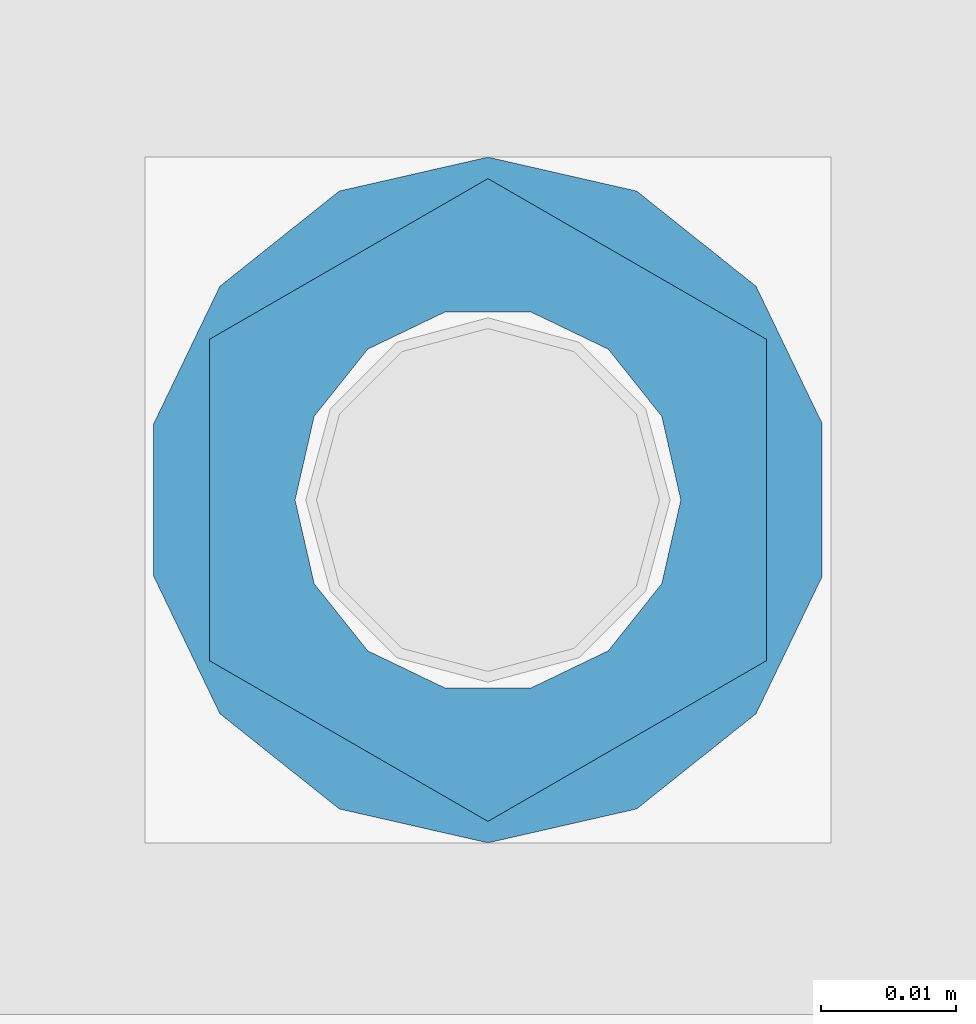
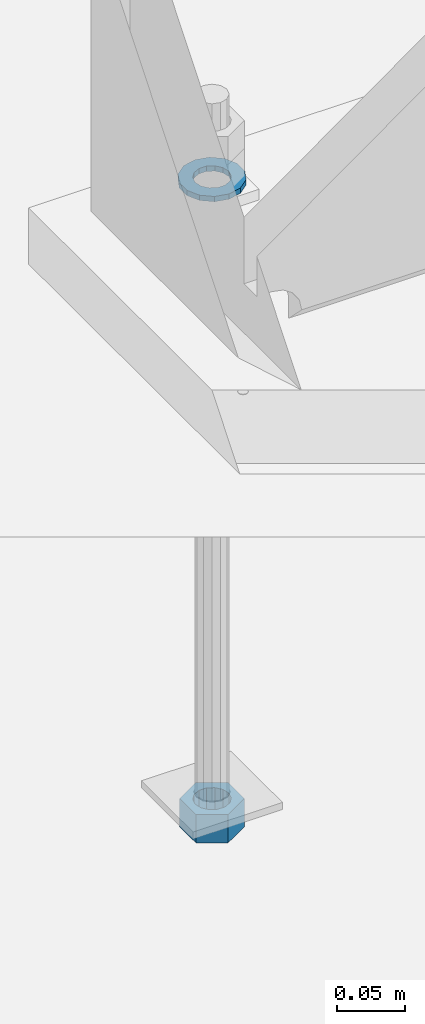
# One storey, part 1024 of 1763: 2 columns, 1 element without a shape of its own.
"""IFC2X3 building model written with IfcOpenShell, lengths in millimetres."""

from ifc_helpers import new_model, si_unit, frame, origin_with_axes, place, context, subcontext, project, spatial, faceted_brep, material, type_object, element, aggregate, save


model = new_model("IFC2X3")

# Units and contexts
model_context = context("Model", 3, precision=1e-05, world=origin_with_axes())
body_context = subcontext(model_context, "Body", "Model", "MODEL_VIEW")
ifc_project = project(units=[si_unit("LENGTHUNIT", "METRE", prefix="MILLI"), si_unit("AREAUNIT", "SQUARE_METRE"), si_unit("VOLUMEUNIT", "CUBIC_METRE"), si_unit("MASSUNIT", "GRAM", prefix="KILO"), si_unit("TIMEUNIT", "SECOND"), si_unit("PLANEANGLEUNIT", "RADIAN"), si_unit("SOLIDANGLEUNIT", "STERADIAN"), si_unit("THERMODYNAMICTEMPERATUREUNIT", "DEGREE_CELSIUS"), si_unit("LUMINOUSINTENSITYUNIT", "LUMEN")], contexts=[model_context])

# Site, building, storey
site_placement = place(None, origin_with_axes())
site = spatial("IfcSite", under=ifc_project, at=site_placement, CompositionType="ELEMENT")
building_placement = place(site_placement, origin_with_axes())
building = spatial("IfcBuilding", under=site, at=building_placement, Name="Undefined", CompositionType="ELEMENT")
storey_placement = place(building_placement, origin_with_axes())
storey = spatial("IfcBuildingStorey", under=building, at=storey_placement, Name="Undefined", CompositionType="ELEMENT", Elevation=0.0)

# Assembly, columns
assembly_placement = place(storey_placement, origin_with_axes())
assembly = element("IfcElementAssembly", 1, at=assembly_placement, inside=storey, Name="TEMPLATE", AssemblyPlace="NOTDEFINED", PredefinedType="RIGID_FRAME")
ifc_material_1 = material(Name="STEEL/A563")
column_type_1 = type_object("IfcColumnType", Name="1_HEAVY_HEX_NUT", PredefinedType="NOTDEFINED")
column_1_placement = place(assembly_placement, frame((-61848.4372736983, 52298.6, -761.999999999996), z_axis=(-1.0, 0.0, 0.0), x_axis=(0.0, 0.0, -1.0)))
column_1 = element("IfcColumn", 2, at=column_1_placement, type_object=column_type_1, material=ifc_material_1, Name="NUT", ObjectType="1_HEAVY_HEX_NUT", context=body_context, shape_type="Brep", body=[
    faceted_brep([(0.0, -23.8099994659424, 0.0), (0.0, -11.9099998474121, -20.6200008392334), (25.4, -11.9099998474121, -20.6200008392334), (25.4, -23.8099994659424, 0.0), (0.0, 11.9099998474121, -20.6200008392334), (25.4, 11.9099998474121, -20.6200008392334), (0.0, 23.8099994659424, 0.0), (25.4, 23.8099994659424, 0.0), (0.0, 11.9099998474121, 20.6200008392334), (25.4, 11.9099998474121, 20.6200008392334), (0.0, -11.9099998474121, 20.6200008392334), (25.4, -11.9099998474121, 20.6200008392334), (0.0, 0.0, 14.289999961853), (0.0, 6.20019861543551, 12.8748450879575), (25.4, 6.20019861543551, 12.8748450879502), (25.4, 0.0, 14.289999961853), (0.0, 11.1723718546418, 8.90966924477834), (25.4, 11.1723718546418, 8.90966924477834), (0.0, 13.9317198278877, 3.17982413774735), (25.4, 13.9317198278877, 3.17982413774007), (0.0, 13.9317198278877, -3.17982413774735), (25.4, 13.9317198278877, -3.17982413774007), (0.0, 11.1723718546418, -8.90966924477834), (25.4, 11.1723718546418, -8.90966924477834), (0.0, 6.20019861543551, -12.8748450879575), (25.4, 6.20019861543551, -12.8748450879502), (0.0, 0.0, -14.289999961853), (25.4, 0.0, -14.289999961853), (0.0, -6.20019861543551, -12.8748450879575), (25.4, -6.20019861543551, -12.8748450879502), (0.0, -11.1723718546418, -8.90966924477834), (25.4, -11.1723718546418, -8.90966924477834), (0.0, -13.9317198278877, -3.17982413774735), (25.4, -13.9317198278877, -3.17982413774007), (0.0, -13.9317198278877, 3.17982413774735), (25.4, -13.9317198278877, 3.17982413774007), (0.0, -11.1723718546418, 8.90966924477834), (25.4, -11.1723718546418, 8.90966924477834), (0.0, -6.20019861543551, 12.8748450879575), (25.4, -6.20019861543551, 12.8748450879502)], [[[0, 1, 2, 3]], [[1, 4, 5, 2]], [[4, 6, 7, 5]], [[6, 8, 9, 7]], [[8, 10, 11, 9]], [[10, 0, 3, 11]], [[12, 13, 14, 15]], [[13, 16, 17, 14]], [[16, 18, 19, 17]], [[18, 20, 21, 19]], [[20, 22, 23, 21]], [[22, 24, 25, 23]], [[24, 26, 27, 25]], [[26, 28, 29, 27]], [[28, 30, 31, 29]], [[30, 32, 33, 31]], [[32, 34, 35, 33]], [[34, 36, 37, 35]], [[36, 38, 39, 37]], [[38, 12, 15, 39]], [[5, 7, 9, 11, 3, 2], [17, 19, 21, 23, 25, 27, 29, 31, 33, 35, 37, 39, 15, 14]], [[10, 8, 6, 4, 1, 0], [38, 36, 34, 32, 30, 28, 26, 24, 22, 20, 18, 16, 13, 12]]]),
])
ifc_material_2 = material(Name="STEEL/F436")
column_type_2 = type_object("IfcColumnType", Name="1_WASHER", PredefinedType="NOTDEFINED")
column_2_placement = place(assembly_placement, frame((-61848.4372736983, 52298.6, -201.612499999996), z_axis=(-1.0, 0.0, 0.0), x_axis=(0.0, 0.0, -1.0)))
column_2 = element("IfcColumn", 3, at=column_2_placement, type_object=column_type_2, material=ifc_material_2, Name="WASHER", ObjectType="1_WASHER", context=body_context, shape_type="Brep", body=[
    faceted_brep([(0.0, -25.4000000000015, 0.0), (0.0, -22.8846089010258, -11.0206468080723), (4.76249999999982, -22.8846089010258, -11.0206468080723), (4.76249999999982, -25.3999996185303, 0.0), (0.0, -15.8366407293724, -19.8585193564359), (4.76249999999982, -15.8366407293724, -19.8585193564359), (0.0, -5.65203163760452, -24.7631685975066), (4.76249999999982, -5.65203163760452, -24.7631685975066), (0.0, 5.65203163760452, -24.7631685975066), (4.76249999999982, 5.65203163760452, -24.7631685975066), (0.0, 15.8366407293724, -19.8585193564359), (4.76249999999982, 15.8366407293724, -19.8585193564359), (0.0, 22.8846089010258, -11.0206468080723), (4.76249999999982, 22.8846089010258, -11.0206468080723), (0.0, 25.4000000000015, 0.0), (4.76249999999982, 25.3999996185303, 0.0), (0.0, 22.8846089010258, 11.0206468080723), (4.76249999999982, 22.8846089010258, 11.0206468080723), (0.0, 15.8366407293724, 19.8585193564359), (4.76249999999982, 15.8366407293724, 19.8585193564359), (0.0, 5.65203163760452, 24.7631685975066), (4.76249999999982, 5.65203163760452, 24.7631685975066), (0.0, -5.65203163760452, 24.7631685975066), (4.76249999999982, -5.65203163760452, 24.7631685975066), (0.0, -15.8366407293724, 19.8585193564359), (4.76249999999982, -15.8366407293724, 19.8585193564359), (0.0, -22.8846089010258, 11.0206468080723), (4.76249999999982, -22.8846089010258, 11.0206468080723), (0.0, 0.0, 14.289999961853), (0.0, 6.20019861543551, 12.8748450879575), (4.76249999999982, 6.20019861543551, 12.8748450879502), (4.76249999999982, 0.0, 14.289999961853), (0.0, 11.1723718546418, 8.90966924477834), (4.76249999999982, 11.1723718546418, 8.90966924477834), (0.0, 13.9317198278877, 3.17982413774735), (4.76249999999982, 13.9317198278877, 3.17982413774007), (0.0, 13.9317198278877, -3.17982413774735), (4.76249999999982, 13.9317198278877, -3.17982413774007), (0.0, 11.1723718546418, -8.90966924477834), (4.76249999999982, 11.1723718546418, -8.90966924477834), (0.0, 6.20019861543551, -12.8748450879575), (4.76249999999982, 6.20019861543551, -12.8748450879502), (0.0, 0.0, -14.289999961853), (4.76249999999982, 0.0, -14.289999961853), (0.0, -6.20019861543551, -12.8748450879575), (4.76249999999982, -6.20019861543551, -12.8748450879502), (0.0, -11.1723718546418, -8.90966924477834), (4.76249999999982, -11.1723718546418, -8.90966924477834), (0.0, -13.9317198278877, -3.17982413774735), (4.76249999999982, -13.9317198278877, -3.17982413774007), (0.0, -13.9317198278877, 3.17982413774735), (4.76249999999982, -13.9317198278877, 3.17982413774007), (0.0, -11.1723718546418, 8.90966924477834), (4.76249999999982, -11.1723718546418, 8.90966924477834), (0.0, -6.20019861543551, 12.8748450879575), (4.76249999999982, -6.20019861543551, 12.8748450879502)], [[[0, 1, 2, 3]], [[1, 4, 5, 2]], [[4, 6, 7, 5]], [[6, 8, 9, 7]], [[8, 10, 11, 9]], [[10, 12, 13, 11]], [[12, 14, 15, 13]], [[14, 16, 17, 15]], [[16, 18, 19, 17]], [[18, 20, 21, 19]], [[20, 22, 23, 21]], [[22, 24, 25, 23]], [[24, 26, 27, 25]], [[26, 0, 3, 27]], [[28, 29, 30, 31]], [[29, 32, 33, 30]], [[32, 34, 35, 33]], [[34, 36, 37, 35]], [[36, 38, 39, 37]], [[38, 40, 41, 39]], [[40, 42, 43, 41]], [[42, 44, 45, 43]], [[44, 46, 47, 45]], [[46, 48, 49, 47]], [[48, 50, 51, 49]], [[50, 52, 53, 51]], [[52, 54, 55, 53]], [[54, 28, 31, 55]], [[5, 7, 9, 11, 13, 15, 17, 19, 21, 23, 25, 27, 3, 2], [33, 35, 37, 39, 41, 43, 45, 47, 49, 51, 53, 55, 31, 30]], [[26, 24, 22, 20, 18, 16, 14, 12, 10, 8, 6, 4, 1, 0], [54, 52, 50, 48, 46, 44, 42, 40, 38, 36, 34, 32, 29, 28]]]),
])
aggregate(assembly, [column_2, column_1])

save(model, "model.ifc")
